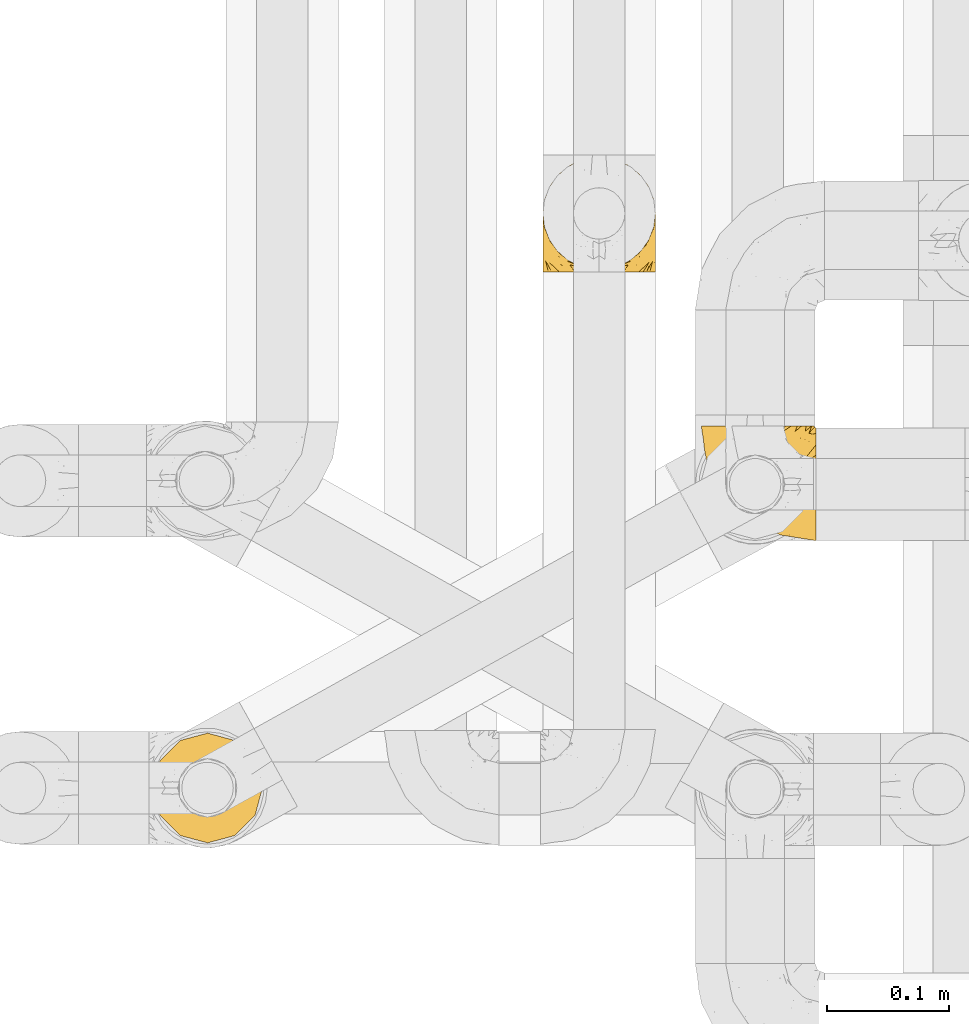
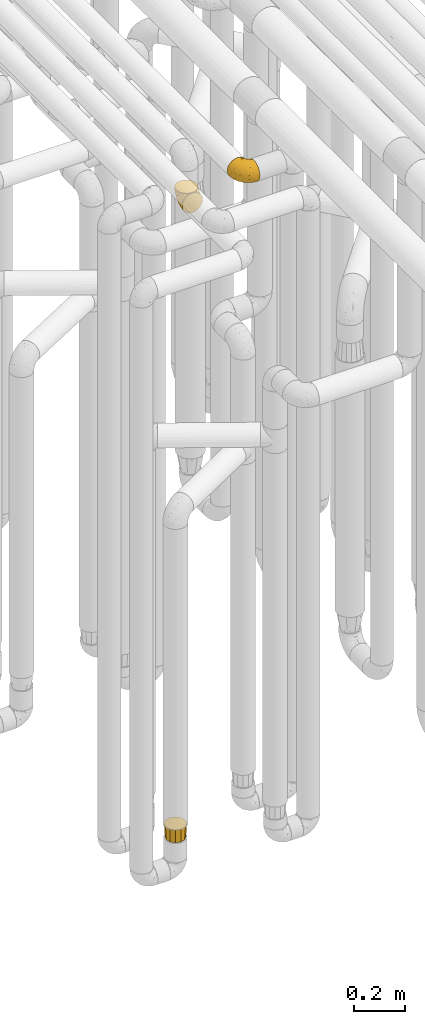
# One storey, part 150 of 827: 3 coverings.
"""IFC2X3 building model written with IfcOpenShell, lengths in millimetres."""

import ifcopenshell
import ifcopenshell.guid

model = None  # the IFC model being written
_history = None  # IfcOwnerHistory: only IFC2X3 demands one
_inside = {}  # id of a spatial element -> (the spatial element, [elements in it])
_under = {}  # id of a project, library or spatial element -> (it, [spatial elements below it])
_declared = {}  # id of a project -> (the project, [libraries it declares])
_typed = {}  # id of a type object -> (the type object, [elements of that type])
_made_of = {}  # id of a material, layer set ... -> (it, [elements and type objects made of it])


def new_model(schema):
    """Start an empty IFC model of exactly this schema.

    Asked for "IFC4X3", IfcOpenShell would pick the latest addendum, in which some entities
    have other attributes; the version numbers below select the first issue.
    IFC2X3 requires an IfcOwnerHistory on every rooted entity: one is made here for all.
    """
    global model, _history
    if schema == "IFC4X3":
        model = ifcopenshell.file(schema_version=(4, 3, 0, 0))
    else:
        model = ifcopenshell.file(schema=schema)
    _inside.clear()
    _under.clear()
    _declared.clear()
    _typed.clear()
    _made_of.clear()
    _history = None
    if model.schema == "IFC2X3":
        org = make("IfcOrganization", Name="unknown")
        user = make(
            "IfcPersonAndOrganization",
            ThePerson=make("IfcPerson", FamilyName="unknown"),
            TheOrganization=org,
        )
        app = make(
            "IfcApplication",
            ApplicationDeveloper=org,
            Version="unknown",
            ApplicationFullName="unknown",
            ApplicationIdentifier="unknown",
        )
        _history = make(
            "IfcOwnerHistory",
            OwningUser=user,
            OwningApplication=app,
            ChangeAction="ADDED",
            CreationDate=0,
        )
    return model


def make(cls, **values):
    """One entity of the class cls with the attributes given. An attribute that is None is left unset."""
    return model.create_entity(
        cls, **{name: value for name, value in values.items() if value is not None}
    )


def entity(cls, *values):
    """Any entity or typed value of the class cls, its attributes in the order of the schema. None: left unset."""
    e = model.create_entity(cls)
    for i, value in enumerate(values):
        if value is not None:
            e[i] = value
    return e


def rooted(cls, **values):
    """An entity with a GlobalId (a new one), such as an element, a storey or a relation."""
    return make(cls, GlobalId=ifcopenshell.guid.new(), OwnerHistory=_history, **values)


def si_unit(unit_type, name, prefix=None):
    """IfcSIUnit, for example si_unit("LENGTHUNIT", "METRE", prefix="MILLI")."""
    return make("IfcSIUnit", UnitType=unit_type, Prefix=prefix, Name=name)


def converted_unit(unit_type, name, factor, base, dimensions=None, offset=None):
    """IfcConversionBasedUnit, such as the inch: factor (a typed value) times the base unit."""
    return make(
        "IfcConversionBasedUnit"
        if offset is None
        else "IfcConversionBasedUnitWithOffset",
        ConversionOffset=offset,
        Dimensions=None
        if dimensions is None
        else entity("IfcDimensionalExponents", *dimensions),
        UnitType=unit_type,
        Name=name,
        ConversionFactor=make(
            "IfcMeasureWithUnit", ValueComponent=factor, UnitComponent=base
        ),
    )


def derived_unit(unit_type, elements):
    """IfcDerivedUnit: a product of units, each with its exponent."""
    return make(
        "IfcDerivedUnit",
        Elements=[
            make("IfcDerivedUnitElement", Unit=unit, Exponent=power)
            for unit, power in elements
        ],
        UnitType=unit_type,
    )


def assignment(units):
    """IfcUnitAssignment: the units of a project."""
    return None if units is None else make("IfcUnitAssignment", Units=units)


def point(xyz):
    """IfcCartesianPoint."""
    return None if xyz is None else make("IfcCartesianPoint", Coordinates=xyz)


def direction(xyz):
    """IfcDirection."""
    return None if xyz is None else make("IfcDirection", DirectionRatios=xyz)


def frame(location, z_axis=None, x_axis=None):
    """IfcAxis2Placement3D, a coordinate frame: its origin and axes. An axis left out is left unset."""
    return make(
        "IfcAxis2Placement3D",
        Location=point(location),
        Axis=direction(z_axis),
        RefDirection=direction(x_axis),
    )


def origin():
    """The frame at (0, 0, 0) with its axes left unset."""
    return frame((0.0, 0.0, 0.0))


def place(relative_to, where):
    """IfcLocalPlacement: puts the frame where relative to a parent placement (None: the world)."""
    return make(
        "IfcLocalPlacement", PlacementRelTo=relative_to, RelativePlacement=where
    )


def context(
    kind, dimensions, precision=None, world=None, true_north=None, identifier=None
):
    """IfcGeometricRepresentationContext, for example the 3D "Model" context."""
    return make(
        "IfcGeometricRepresentationContext",
        ContextIdentifier=identifier,
        ContextType=kind,
        CoordinateSpaceDimension=dimensions,
        Precision=precision,
        WorldCoordinateSystem=world,
        TrueNorth=true_north,
    )


def subcontext(parent, identifier, kind, view, scale=None):
    """IfcGeometricRepresentationSubContext, for example "Body" below "Model"."""
    return make(
        "IfcGeometricRepresentationSubContext",
        ContextIdentifier=identifier,
        ContextType=kind,
        ParentContext=parent,
        TargetScale=scale,
        TargetView=view,
    )


def project(units=None, contexts=None):
    """IfcProject with its units and contexts."""
    return rooted(
        "IfcProject",
        Name="project",
        RepresentationContexts=contexts,
        UnitsInContext=assignment(units),
    )


def spatial(cls, under=None, at=None, **own):
    """A site, building, storey or space (cls), placed at a placement, below another one or the project."""
    s = rooted(cls, ObjectPlacement=at, **own)
    if under is not None:
        _under.setdefault(under.id(), (under, []))[1].append(s)
    return s


def faces_of(points, faces, orient=None, outer=None):
    """IfcFace entities. A face is a list of loops; a loop is a list of indices into points, from 0.

    orient and outer hold one flag for each loop. By default every Orientation is true, the
    first loop of a face is its IfcFaceOuterBound and the others are IfcFaceBound.
    """
    made = []
    for i, loops in enumerate(faces):
        bounds = []
        for j, loop in enumerate(loops):
            is_outer = j == 0 if outer is None else outer[i][j]
            bounds.append(
                make(
                    "IfcFaceOuterBound" if is_outer else "IfcFaceBound",
                    Bound=make("IfcPolyLoop", Polygon=[points[k] for k in loop]),
                    Orientation=True if orient is None else orient[i][j],
                )
            )
        made.append(make("IfcFace", Bounds=bounds))
    return made


def faceted_brep(points, faces, orient=None, outer=None, voids=None):
    """IfcFacetedBrep: a solid bounded by flat faces; with voids (closed shells), ...WithVoids."""
    shared = [point(p) for p in points]
    hull = make("IfcClosedShell", CfsFaces=faces_of(shared, faces, orient, outer))
    if voids is None:
        return make("IfcFacetedBrep", Outer=hull)
    return make(
        "IfcFacetedBrepWithVoids",
        Outer=hull,
        Voids=[
            make(cls, CfsFaces=faces_of(shared, fs, o, b)) for cls, fs, o, b in voids
        ],
    )


def shape(context_of_items, identifier, shape_type, items):
    """IfcShapeRepresentation: the items that make up one representation, for example the "Body"."""
    return make(
        "IfcShapeRepresentation",
        ContextOfItems=context_of_items,
        RepresentationIdentifier=identifier,
        RepresentationType=shape_type,
        Items=items,
    )


def made_of(thing, what):
    """Note that an element or type object is made of a material, layer set ...; save() writes the relation."""
    if what is not None:
        _made_of.setdefault(what.id(), (what, []))[1].append(thing)
    return thing


def element(
    cls,
    number,
    at=None,
    inside=None,
    cuts=None,
    type_object=None,
    material=None,
    context=None,
    identifier="Body",
    shape_type=None,
    held_by="IfcProductDefinitionShape",
    body=None,
    shapes=None,
    **own,
):
    """One element of the class cls, such as IfcWall. Its Tag is "e" and its number.

    at: its placement. inside: the storey or other place that contains it. cuts: it is an
    opening in that element (IfcRelVoidsElement). A single representation is given by context,
    identifier, shape_type and body (its items); several are given by shapes. held_by: the class
    of the entity that holds the representations. save() writes the other relations.
    """
    e = rooted(cls, Tag="e%d" % number, ObjectPlacement=at, **own)
    if body is not None:
        shapes = [shape(context, identifier, shape_type, body)]
    if shapes is not None:
        e.Representation = make(held_by, Representations=shapes)
    if inside is not None:
        _inside.setdefault(inside.id(), (inside, []))[1].append(e)
    if cuts is not None:
        rooted(
            "IfcRelVoidsElement", RelatingBuildingElement=cuts, RelatedOpeningElement=e
        )
    if type_object is not None:
        _typed.setdefault(type_object.id(), (type_object, []))[1].append(e)
    return made_of(e, material)


def aggregate(whole, parts):
    """IfcRelAggregates: a whole, such as a stair, and the parts it consists of."""
    return rooted("IfcRelAggregates", RelatingObject=whole, RelatedObjects=parts)


def save(model, path):
    """Write the relations noted so far, then the file.

    IfcRelAggregates (storeys below a building ...), IfcRelContainedInSpatialStructure (elements
    in a storey), IfcRelDefinesByType, IfcRelAssociatesMaterial and IfcRelDeclares: one each for
    every whole, place, type object, material and project.
    """
    for whole, parts in _under.values():
        aggregate(whole, parts)
    for where, things in _inside.values():
        rooted(
            "IfcRelContainedInSpatialStructure",
            RelatedElements=things,
            RelatingStructure=where,
        )
    for kind, things in _typed.values():
        rooted("IfcRelDefinesByType", RelatedObjects=things, RelatingType=kind)
    for what, things in _made_of.values():
        rooted("IfcRelAssociatesMaterial", RelatedObjects=things, RelatingMaterial=what)
    for by, libraries in _declared.values():
        rooted("IfcRelDeclares", RelatingContext=by, RelatedDefinitions=libraries)
    model.write(path)


model = new_model("IFC2X3")

# Units and contexts
model_context = context("Model", 3, precision=0.01, world=origin(), true_north=direction((6.12303176911189e-17, 1.0)))
body_context = subcontext(model_context, "Body", "Model", "MODEL_VIEW")
ifc_project = project(units=[si_unit("LENGTHUNIT", "METRE", prefix="MILLI"), si_unit("AREAUNIT", "SQUARE_METRE"), si_unit("VOLUMEUNIT", "CUBIC_METRE"), converted_unit("PLANEANGLEUNIT", "DEGREE", entity("IfcRatioMeasure", 0.0174532925199433), si_unit("PLANEANGLEUNIT", "RADIAN"), dimensions=[0, 0, 0, 0, 0, 0, 0]), si_unit("MASSUNIT", "GRAM", prefix="KILO"), derived_unit("MASSDENSITYUNIT", [(si_unit("MASSUNIT", "GRAM", prefix="KILO"), 1), (si_unit("LENGTHUNIT", "METRE"), -3)]), derived_unit("MOMENTOFINERTIAUNIT", [(si_unit("LENGTHUNIT", "METRE"), 4)]), si_unit("TIMEUNIT", "SECOND"), si_unit("FREQUENCYUNIT", "HERTZ"), si_unit("THERMODYNAMICTEMPERATUREUNIT", "DEGREE_CELSIUS"), derived_unit("THERMALTRANSMITTANCEUNIT", [(si_unit("MASSUNIT", "GRAM", prefix="KILO"), 1), (si_unit("THERMODYNAMICTEMPERATUREUNIT", "KELVIN"), -1), (si_unit("TIMEUNIT", "SECOND"), -3)]), derived_unit("VOLUMETRICFLOWRATEUNIT", [(si_unit("LENGTHUNIT", "METRE"), 3), (si_unit("TIMEUNIT", "SECOND"), -1)]), derived_unit("MASSFLOWRATEUNIT", [(si_unit("MASSUNIT", "GRAM", prefix="KILO"), 1), (si_unit("TIMEUNIT", "SECOND"), -1)]), derived_unit("ROTATIONALFREQUENCYUNIT", [(si_unit("TIMEUNIT", "SECOND"), -1)]), si_unit("ELECTRICCURRENTUNIT", "AMPERE"), si_unit("ELECTRICVOLTAGEUNIT", "VOLT"), si_unit("POWERUNIT", "WATT"), si_unit("FORCEUNIT", "NEWTON", prefix="KILO"), si_unit("ILLUMINANCEUNIT", "LUX"), si_unit("LUMINOUSFLUXUNIT", "LUMEN"), si_unit("LUMINOUSINTENSITYUNIT", "CANDELA"), derived_unit("USERDEFINED", [(si_unit("MASSUNIT", "GRAM", prefix="KILO"), -1), (si_unit("LENGTHUNIT", "METRE"), -2), (si_unit("TIMEUNIT", "SECOND"), 3), (si_unit("LUMINOUSFLUXUNIT", "LUMEN"), 1)]), derived_unit("LINEARVELOCITYUNIT", [(si_unit("LENGTHUNIT", "METRE"), 1), (si_unit("TIMEUNIT", "SECOND"), -1)]), si_unit("PRESSUREUNIT", "PASCAL"), derived_unit("USERDEFINED", [(si_unit("LENGTHUNIT", "METRE"), -2), (si_unit("MASSUNIT", "GRAM", prefix="KILO"), 1), (si_unit("TIMEUNIT", "SECOND"), -2)]), derived_unit("LINEARFORCEUNIT", [(si_unit("MASSUNIT", "GRAM", prefix="KILO"), 1), (si_unit("LENGTHUNIT", "METRE"), 1), (si_unit("TIMEUNIT", "SECOND"), -2), (si_unit("LENGTHUNIT", "METRE"), -1)]), derived_unit("PLANARFORCEUNIT", [(si_unit("MASSUNIT", "GRAM", prefix="KILO"), 1), (si_unit("LENGTHUNIT", "METRE"), 1), (si_unit("TIMEUNIT", "SECOND"), -2), (si_unit("LENGTHUNIT", "METRE"), -2)])], contexts=[model_context])

# Site, building, storey
site_placement = place(None, origin())
site = spatial("IfcSite", under=ifc_project, at=site_placement, CompositionType="ELEMENT")
building_placement = place(site_placement, origin())
building = spatial("IfcBuilding", under=site, at=building_placement, CompositionType="ELEMENT")
storey_placement = place(building_placement, frame((0.0, 0.0, 28200.0)))
storey = spatial("IfcBuildingStorey", under=building, at=storey_placement, Name="08", CompositionType="ELEMENT", Elevation=28200.0)

# Coverings
covering_1_placement = place(storey_placement, frame((35552.3, 10778.78, 3152.2)))
element("IfcCovering", 1, at=covering_1_placement, inside=storey, Name=":ADSK_", ObjectType=":ADSK_", PredefinedType="INSULATION", context=body_context, shape_type="Brep", body=[
    faceted_brep([(11.68, 1.6, 18.98), (19.0, 1.6, 11.67), (27.76, 1.6, 6.17), (37.52, 1.6, 2.75), (47.8, 1.6, 1.6), (58.08, 1.6, 2.75), (67.85, 1.6, 6.17), (76.61, 1.6, 11.68), (83.92, 1.6, 19.0), (89.42, 1.6, 27.76), (92.84, 1.6, 37.52), (94.0, 1.6, 47.8), (93.53, 1.6, 51.94), (93.18, 1.6, 55.01), (92.84, 1.6, 58.08), (91.13, 1.6, 62.96), (89.42, 1.6, 67.85), (86.66, 1.6, 72.23), (83.91, 1.6, 76.61), (80.25, 1.6, 80.26), (76.59, 1.6, 83.92), (67.83, 1.6, 89.42), (62.95, 1.6, 91.13), (58.07, 1.6, 92.84), (47.8, 1.6, 94.0), (37.51, 1.6, 92.84), (32.63, 1.6, 91.13), (27.74, 1.6, 89.42), (18.98, 1.6, 83.91), (15.33, 1.6, 80.25), (11.67, 1.6, 76.59), (8.92, 1.6, 72.21), (6.17, 1.6, 67.83), (4.46, 1.6, 62.95), (2.75, 1.6, 58.07), (2.41, 1.6, 55.0), (2.06, 1.6, 51.94), (1.6, 1.6, 47.8), (2.75, 1.6, 37.51), (6.17, 1.6, 27.74), (47.8, 3.4, 95.8), (59.75, 4.97, 95.8), (70.9, 9.58, 95.8), (75.68, 13.26, 95.8), (80.46, 16.93, 95.8), (84.13, 21.71, 95.8), (87.81, 26.5, 95.8), (90.11, 32.07, 95.8), (92.42, 37.64, 95.8), (92.9, 41.25, 95.8), (93.17, 43.34, 95.8), (93.45, 45.42, 95.8), (94.0, 49.6, 95.8), (92.42, 61.55, 95.8), (87.81, 72.7, 95.8), (80.46, 82.26, 95.8), (70.9, 89.61, 95.8), (59.75, 94.22, 95.8), (47.8, 95.8, 95.8), (35.84, 94.22, 95.8), (24.7, 89.61, 95.8), (15.13, 82.26, 95.8), (7.78, 72.7, 95.8), (3.17, 61.55, 95.8), (1.6, 49.6, 95.8), (2.14, 45.42, 95.8), (2.69, 41.25, 95.8), (3.17, 37.64, 95.8), (5.48, 32.07, 95.8), (7.78, 26.5, 95.8), (11.46, 21.71, 95.8), (15.13, 16.93, 95.8), (19.91, 13.26, 95.8), (24.7, 9.58, 95.8), (35.84, 4.97, 95.8), (23.61, 81.55, 60.58), (31.99, 90.4, 74.11), (35.87, 83.0, 51.59), (47.8, 91.18, 66.69), (40.43, 93.13, 76.19), (47.8, 94.0, 84.43), (31.83, 66.19, 31.2), (23.37, 70.92, 42.88), (21.41, 85.95, 79.41), (3.07, 49.74, 60.7), (1.6, 35.54, 61.85), (1.6, 38.14, 65.75), (1.6, 40.74, 69.64), (1.6, 43.34, 73.53), (1.6, 45.94, 77.43), (13.45, 77.59, 74.59), (15.25, 71.17, 54.72), (8.07, 65.81, 64.18), (16.0, 59.03, 37.94), (17.34, 45.85, 25.89), (10.58, 45.79, 34.73), (5.34, 41.42, 42.89), (2.39, 34.51, 49.83), (8.36, 56.04, 48.58), (10.04, 15.15, 22.41), (2.59, 56.51, 78.69), (6.28, 68.39, 81.64), (34.28, 23.33, 6.22), (38.73, 42.86, 12.11), (27.25, 39.42, 14.81), (29.88, 53.58, 21.61), (38.6, 59.17, 22.41), (23.44, 59.06, 30.12), (25.25, 22.63, 10.01), (17.23, 20.55, 15.36), (47.8, 12.96, 3.39), (47.8, 56.96, 19.59), (47.8, 67.38, 30.01), (2.53, 18.72, 41.19), (1.6, 5.33, 48.54), (1.6, 9.07, 49.28), (1.6, 11.79, 49.82), (1.6, 14.51, 50.37), (1.6, 17.24, 50.91), (1.6, 19.96, 51.45), (5.71, 21.03, 31.61), (1.6, 46.48, 80.15), (1.6, 47.03, 82.88), (1.6, 47.57, 85.6), (1.6, 48.11, 88.32), (1.6, 48.48, 90.19), (1.6, 48.85, 92.06), (47.8, 30.7, 6.21), (1.6, 23.86, 54.05), (1.6, 27.75, 56.65), (1.6, 31.64, 59.25), (11.89, 31.26, 24.66), (47.8, 77.8, 40.43), (39.69, 72.75, 35.17), (47.8, 43.83, 12.9), (47.8, 84.49, 53.56), (13.84, 14.58, 85.34), (9.16, 16.17, 78.44), (15.79, 10.82, 84.37), (25.75, 4.64, 89.05), (16.09, 7.71, 82.76), (7.51, 25.13, 86.31), (3.99, 32.66, 83.73), (2.66, 34.94, 77.31), (3.16, 36.76, 87.78), (2.35, 40.48, 87.91), (2.23, 39.25, 81.29), (38.35, 3.69, 93.97), (6.18, 13.99, 70.76), (2.7, 21.85, 63.67), (2.93, 17.93, 62.62), (16.01, 15.11, 90.64), (9.08, 21.14, 84.08), (11.68, 7.21, 77.45), (6.83, 9.47, 70.34), (4.65, 32.27, 88.72), (3.65, 25.68, 71.28), (3.61, 22.18, 68.09), (12.8, 18.79, 91.07), (2.43, 10.12, 57.47), (21.65, 10.45, 91.35), (3.7, 11.29, 62.99), (47.8, 2.87, 94.52), (3.37, 31.16, 76.47), (9.3, 12.7, 76.28), (7.03, 6.31, 69.96), (7.87, 25.62, 89.86), (7.26, 21.18, 78.94), (3.41, 28.81, 73.51), (23.81, 7.45, 89.62), (88.32, 21.17, 78.96), (86.42, 16.17, 78.46), (91.93, 25.69, 71.31), (94.0, 48.85, 92.06), (94.0, 47.03, 82.88), (94.0, 47.57, 85.6), (94.0, 48.11, 88.32), (57.24, 3.69, 93.97), (71.76, 7.44, 89.63), (94.0, 14.51, 50.37), (94.0, 11.79, 49.82), (94.0, 5.33, 48.54), (94.0, 9.07, 49.28), (79.49, 7.71, 82.77), (88.75, 9.47, 70.36), (92.93, 34.94, 77.31), (92.22, 31.16, 76.47), (94.0, 40.74, 69.64), (94.0, 38.14, 65.75), (82.79, 18.79, 91.06), (92.43, 36.76, 87.78), (93.24, 40.48, 87.91), (69.82, 4.63, 89.06), (86.5, 21.14, 84.09), (79.57, 15.11, 90.65), (81.74, 14.58, 85.35), (94.0, 43.34, 73.53), (94.0, 45.94, 77.43), (93.36, 39.25, 81.29), (83.9, 7.21, 77.46), (86.28, 12.69, 76.29), (93.16, 10.14, 57.47), (92.88, 21.81, 63.71), (91.98, 22.19, 68.11), (89.41, 14.0, 70.77), (88.82, 6.66, 69.52), (92.66, 17.92, 62.64), (73.93, 10.45, 91.35), (94.0, 31.64, 59.25), (79.5, 10.64, 84.6), (91.89, 11.31, 62.98), (94.0, 19.96, 51.45), (94.0, 23.86, 54.05), (94.0, 27.75, 56.65), (91.6, 32.66, 83.73), (94.0, 46.48, 80.15), (90.94, 32.27, 88.72), (88.08, 25.13, 86.3), (94.0, 35.54, 61.85), (92.16, 28.77, 73.56), (86.13, 23.36, 91.36), (94.0, 17.24, 50.91), (93.2, 47.58, 62.87), (55.16, 93.13, 76.19), (82.02, 77.44, 73.57), (84.29, 66.78, 56.07), (76.94, 71.68, 49.77), (68.33, 74.96, 44.73), (71.98, 81.55, 60.58), (92.52, 36.7, 47.64), (92.9, 56.9, 78.32), (59.72, 83.0, 51.59), (63.6, 90.4, 74.11), (88.89, 67.83, 76.04), (74.18, 85.95, 79.41), (68.35, 39.41, 14.82), (61.33, 23.33, 6.22), (56.86, 42.87, 12.12), (68.62, 53.92, 23.51), (63.76, 66.19, 31.2), (72.19, 64.12, 34.96), (88.69, 33.13, 33.86), (92.19, 23.1, 38.94), (89.75, 16.98, 30.23), (55.9, 72.75, 35.17), (77.99, 23.77, 15.85), (85.21, 18.41, 22.59), (74.99, 43.7, 21.56), (90.23, 54.53, 55.94), (59.86, 55.72, 20.67), (70.75, 17.73, 9.19), (81.72, 38.98, 25.79), (86.53, 50.28, 41.16), (79.6, 59.02, 37.95)], [[[0, 1, 2, 3, 4, 5, 6, 7, 8, 9, 10, 11, 12, 13, 14, 15, 16, 17, 18, 19, 20, 21, 22, 23, 24, 25, 26, 27, 28, 29, 30, 31, 32, 33, 34, 35, 36, 37, 38, 39]], [[40, 41, 42, 43, 44, 45, 46, 47, 48, 49, 50, 51, 52, 53, 54, 55, 56, 57, 58, 59, 60, 61, 62, 63, 64, 65, 66, 67, 68, 69, 70, 71, 72, 73, 74]], [[75, 76, 77]], [[78, 79, 80]], [[77, 81, 82]], [[76, 75, 83]], [[84, 85, 86, 87, 88, 89]], [[90, 91, 92]], [[76, 60, 59]], [[93, 94, 95]], [[90, 62, 61]], [[83, 61, 60]], [[96, 97, 84]], [[98, 93, 95]], [[0, 39, 99]], [[100, 84, 89]], [[62, 101, 63]], [[2, 102, 3]], [[92, 84, 100]], [[103, 102, 104]], [[103, 105, 106]], [[93, 107, 94]], [[1, 108, 2]], [[92, 101, 90]], [[108, 1, 109]], [[102, 110, 3]], [[93, 82, 107]], [[102, 108, 104]], [[111, 106, 112]], [[109, 0, 99]], [[113, 37, 114, 115, 116, 117, 118, 119]], [[120, 38, 113]], [[100, 89, 121, 122, 123, 124, 125, 126, 64]], [[127, 102, 103]], [[97, 119, 128, 129, 130, 85]], [[99, 120, 131]], [[132, 133, 77]], [[59, 80, 79]], [[1, 0, 109]], [[98, 84, 92]], [[94, 109, 131]], [[120, 39, 38]], [[93, 91, 82]], [[104, 94, 105]], [[97, 113, 119]], [[95, 120, 96]], [[83, 90, 61]], [[91, 93, 98]], [[64, 63, 100]], [[100, 63, 101]], [[77, 76, 79]], [[133, 106, 81]], [[84, 97, 85]], [[113, 96, 120]], [[113, 97, 96]], [[37, 113, 38]], [[110, 102, 127]], [[110, 4, 3]], [[103, 111, 134, 127]], [[90, 75, 91]], [[82, 81, 107]], [[91, 75, 82]], [[77, 82, 75]], [[76, 83, 60]], [[90, 83, 75]], [[105, 107, 81]], [[94, 131, 95]], [[105, 94, 107]], [[109, 94, 104]], [[120, 95, 131]], [[98, 95, 96]], [[84, 98, 96]], [[98, 92, 91]], [[106, 105, 81]], [[103, 104, 105]], [[112, 106, 133]], [[103, 106, 111]], [[112, 133, 132]], [[81, 77, 133]], [[77, 78, 135, 132]], [[120, 99, 39]], [[109, 99, 131]], [[59, 58, 80]], [[59, 79, 76]], [[90, 101, 62]], [[100, 101, 92]], [[2, 108, 102]], [[109, 104, 108]], [[78, 77, 79]], [[136, 137, 138]], [[27, 139, 140]], [[141, 142, 143]], [[144, 145, 121]], [[146, 89, 88]], [[147, 139, 25]], [[148, 149, 150]], [[136, 151, 152]], [[147, 40, 74]], [[24, 147, 25]], [[153, 148, 154]], [[33, 116, 34]], [[73, 72, 151]], [[114, 37, 36, 35, 34, 116, 115]], [[146, 155, 144]], [[156, 85, 130]], [[157, 149, 148]], [[151, 158, 152]], [[117, 33, 159]], [[29, 153, 154]], [[160, 74, 73]], [[161, 128, 119]], [[65, 64, 126, 125, 124, 123, 122, 67, 66]], [[162, 147, 24]], [[27, 140, 28]], [[149, 129, 150]], [[139, 27, 26, 25]], [[68, 144, 69]], [[129, 128, 150]], [[163, 87, 86]], [[130, 129, 149]], [[122, 145, 67]], [[153, 164, 148]], [[161, 119, 159]], [[165, 30, 154]], [[150, 154, 148]], [[128, 161, 150]], [[30, 165, 31]], [[145, 144, 68]], [[89, 146, 144]], [[87, 163, 143]], [[166, 155, 142]], [[88, 87, 143]], [[161, 154, 150]], [[154, 30, 29]], [[29, 28, 153]], [[28, 140, 153]], [[164, 153, 140]], [[140, 137, 164]], [[157, 148, 164]], [[156, 130, 157]], [[164, 137, 157]], [[157, 137, 156]], [[167, 137, 136]], [[168, 85, 156]], [[152, 168, 167]], [[167, 168, 156]], [[163, 152, 141]], [[71, 158, 72]], [[152, 167, 136]], [[88, 142, 146]], [[144, 155, 69]], [[146, 142, 155]], [[70, 166, 71]], [[142, 141, 166]], [[70, 69, 155]], [[141, 158, 71]], [[160, 73, 151]], [[138, 137, 140]], [[160, 136, 169]], [[136, 160, 151]], [[74, 160, 169]], [[152, 158, 141]], [[151, 72, 158]], [[168, 152, 163]], [[137, 167, 156]], [[163, 86, 168]], [[85, 168, 86]], [[116, 33, 117]], [[130, 149, 157]], [[67, 145, 68]], [[121, 89, 144]], [[145, 122, 121]], [[40, 147, 162]], [[169, 147, 74]], [[159, 33, 32]], [[161, 159, 32]], [[159, 119, 118, 117]], [[139, 147, 169]], [[139, 169, 138]], [[161, 32, 31]], [[141, 143, 163]], [[88, 143, 142]], [[71, 166, 141]], [[155, 166, 70]], [[139, 138, 140]], [[169, 136, 138]], [[154, 161, 165]], [[161, 31, 165]], [[170, 171, 172]], [[173, 52, 51, 50, 49, 48, 174, 175, 176]], [[177, 178, 41]], [[179, 15, 180]], [[12, 11, 181, 182, 180, 14, 13]], [[183, 21, 20]], [[19, 18, 184]], [[185, 186, 187]], [[186, 188, 187]], [[43, 189, 44]], [[190, 191, 47]], [[23, 22, 21, 192]], [[193, 194, 195]], [[40, 162, 177]], [[196, 197, 198]], [[24, 23, 177]], [[199, 200, 183]], [[201, 15, 179]], [[47, 46, 190]], [[202, 203, 204]], [[203, 172, 171]], [[205, 206, 184]], [[207, 41, 178]], [[16, 15, 201]], [[14, 180, 15]], [[204, 203, 200]], [[208, 203, 202]], [[162, 24, 177]], [[48, 47, 191]], [[198, 197, 190]], [[199, 184, 204]], [[171, 195, 209]], [[210, 211, 212]], [[206, 212, 213]], [[205, 17, 210]], [[184, 206, 204]], [[210, 212, 206]], [[185, 196, 214]], [[190, 215, 191]], [[216, 45, 214]], [[186, 217, 193]], [[190, 216, 198]], [[199, 20, 19]], [[196, 185, 187]], [[199, 183, 20]], [[184, 199, 19]], [[199, 204, 200]], [[206, 202, 204]], [[171, 183, 200]], [[203, 208, 172]], [[172, 208, 218]], [[171, 200, 203]], [[218, 188, 219]], [[195, 170, 193]], [[217, 186, 185]], [[193, 219, 186]], [[193, 170, 219]], [[207, 194, 42]], [[217, 220, 189]], [[216, 190, 46]], [[214, 196, 198]], [[44, 220, 45]], [[214, 198, 216]], [[216, 46, 45]], [[214, 45, 220]], [[42, 194, 43]], [[189, 193, 217]], [[207, 195, 194]], [[209, 195, 178]], [[41, 207, 42]], [[195, 207, 178]], [[43, 194, 189]], [[193, 189, 194]], [[171, 170, 195]], [[170, 172, 219]], [[218, 219, 172]], [[188, 186, 219]], [[206, 213, 202]], [[208, 202, 213]], [[201, 210, 16]], [[215, 190, 197]], [[215, 174, 191]], [[174, 48, 191]], [[201, 179, 221, 211]], [[210, 201, 211]], [[23, 192, 177]], [[40, 177, 41]], [[183, 209, 192]], [[183, 192, 21]], [[192, 178, 177]], [[205, 18, 17]], [[17, 16, 210]], [[217, 185, 214]], [[189, 220, 44]], [[214, 220, 217]], [[192, 209, 178]], [[171, 209, 183]], [[206, 205, 210]], [[18, 205, 184]], [[222, 197, 196, 187, 188, 218]], [[57, 223, 80]], [[224, 225, 226]], [[226, 227, 228]], [[229, 218, 208, 213, 212, 211]], [[230, 52, 173, 176, 175, 174, 215, 197]], [[231, 232, 228]], [[231, 78, 223]], [[223, 57, 232]], [[224, 233, 225]], [[233, 54, 53]], [[234, 232, 56]], [[56, 55, 234]], [[234, 224, 228]], [[235, 236, 237]], [[224, 55, 54]], [[238, 239, 240]], [[52, 230, 53]], [[241, 242, 243]], [[227, 244, 231]], [[11, 10, 242]], [[236, 6, 5]], [[7, 245, 8]], [[8, 246, 9]], [[238, 247, 235]], [[222, 229, 248]], [[242, 211, 221, 179, 180, 182, 181, 11]], [[233, 53, 230]], [[111, 112, 249]], [[250, 6, 236]], [[246, 251, 241]], [[6, 250, 7]], [[127, 236, 110]], [[248, 229, 252]], [[246, 8, 245]], [[235, 245, 250]], [[236, 5, 110]], [[235, 249, 238]], [[237, 236, 127]], [[243, 9, 246]], [[252, 229, 241]], [[56, 232, 57]], [[222, 230, 197]], [[225, 248, 252]], [[248, 233, 230]], [[54, 233, 224]], [[231, 228, 227]], [[244, 132, 231]], [[248, 225, 233]], [[226, 225, 253]], [[235, 250, 236]], [[245, 7, 250]], [[251, 246, 245]], [[243, 246, 241]], [[247, 245, 235]], [[252, 251, 253]], [[229, 222, 218]], [[230, 222, 248]], [[5, 4, 110]], [[237, 127, 134, 111]], [[238, 249, 239]], [[224, 234, 55]], [[232, 234, 228]], [[242, 241, 229]], [[10, 9, 243]], [[211, 242, 229]], [[10, 243, 242]], [[80, 223, 78]], [[80, 58, 57]], [[231, 223, 232]], [[227, 240, 239]], [[224, 226, 228]], [[240, 226, 253]], [[227, 239, 244]], [[226, 240, 227]], [[251, 247, 253]], [[240, 253, 247]], [[249, 235, 237]], [[237, 111, 249]], [[112, 132, 244]], [[112, 244, 249]], [[78, 231, 132, 135]], [[249, 244, 239]], [[247, 238, 240]], [[245, 247, 251]], [[251, 252, 241]], [[225, 252, 253]]]),
])
covering_2_placement = place(storey_placement, frame((35682.24, 10558.41, 3352.2)))
element("IfcCovering", 2, at=covering_2_placement, inside=storey, Name=":ADSK_", ObjectType=":ADSK_", PredefinedType="INSULATION", context=body_context, shape_type="Brep", body=[
    faceted_brep([(95.8, 18.98, 83.91), (95.8, 11.67, 76.59), (95.8, 6.17, 67.83), (95.8, 2.75, 58.07), (95.8, 1.6, 47.8), (95.8, 2.75, 37.51), (95.8, 6.17, 27.74), (95.8, 11.68, 18.98), (95.8, 19.0, 11.67), (95.8, 27.76, 6.17), (95.8, 37.52, 2.75), (95.8, 47.8, 1.6), (95.8, 51.94, 2.06), (95.8, 55.01, 2.41), (95.8, 58.08, 2.75), (95.8, 62.96, 4.46), (95.8, 67.85, 6.17), (95.8, 72.23, 8.93), (95.8, 76.61, 11.68), (95.8, 80.26, 15.34), (95.8, 83.92, 19.0), (95.8, 89.42, 27.76), (95.8, 91.13, 32.64), (95.8, 92.84, 37.52), (95.8, 94.0, 47.8), (95.8, 92.84, 58.08), (95.8, 91.13, 62.96), (95.8, 89.42, 67.85), (95.8, 83.91, 76.61), (95.8, 80.25, 80.26), (95.8, 76.59, 83.92), (95.8, 72.21, 86.67), (95.8, 67.83, 89.42), (95.8, 62.95, 91.13), (95.8, 58.07, 92.84), (95.8, 55.0, 93.18), (95.8, 51.94, 93.53), (95.8, 47.8, 94.0), (95.8, 37.51, 92.84), (95.8, 27.74, 89.42), (94.0, 95.8, 47.8), (92.42, 95.8, 35.84), (87.81, 95.8, 24.7), (84.13, 95.8, 19.91), (80.46, 95.8, 15.13), (75.68, 95.8, 11.46), (70.9, 95.8, 7.78), (65.32, 95.8, 5.48), (59.75, 95.8, 3.17), (56.14, 95.8, 2.69), (54.06, 95.8, 2.42), (51.97, 95.8, 2.14), (47.8, 95.8, 1.6), (35.84, 95.8, 3.17), (24.7, 95.8, 7.78), (15.13, 95.8, 15.13), (7.78, 95.8, 24.7), (3.17, 95.8, 35.84), (1.6, 95.8, 47.8), (3.17, 95.8, 59.75), (7.78, 95.8, 70.9), (15.13, 95.8, 80.46), (24.7, 95.8, 87.81), (35.84, 95.8, 92.42), (47.8, 95.8, 94.0), (51.97, 95.8, 93.45), (56.14, 95.8, 92.9), (59.75, 95.8, 92.42), (65.32, 95.8, 90.11), (70.9, 95.8, 87.81), (75.68, 95.8, 84.13), (80.46, 95.8, 80.46), (84.13, 95.8, 75.68), (87.81, 95.8, 70.9), (92.42, 95.8, 59.75), (15.84, 60.58, 71.98), (6.99, 74.11, 63.6), (14.39, 51.59, 59.72), (6.21, 66.69, 47.8), (4.26, 76.19, 55.16), (3.39, 84.43, 47.8), (31.2, 31.2, 63.76), (26.47, 42.88, 72.22), (11.44, 79.41, 74.18), (47.66, 60.7, 92.52), (61.85, 61.85, 94.0), (59.25, 65.75, 94.0), (56.65, 69.64, 94.0), (54.05, 73.53, 94.0), (51.45, 77.43, 94.0), (19.8, 74.59, 82.14), (26.22, 54.72, 80.34), (31.58, 64.18, 87.52), (38.36, 37.94, 79.59), (51.54, 25.89, 78.25), (51.6, 34.73, 85.01), (55.97, 42.89, 90.25), (62.88, 49.83, 93.2), (41.35, 48.58, 87.23), (82.24, 22.41, 85.55), (40.88, 78.69, 93.0), (29.0, 81.64, 89.31), (74.06, 6.22, 61.31), (54.53, 12.11, 56.86), (57.98, 14.81, 68.34), (43.81, 21.61, 65.71), (38.22, 22.41, 56.99), (38.33, 30.12, 72.15), (74.76, 10.01, 70.34), (76.85, 15.36, 78.36), (84.43, 3.39, 47.8), (40.43, 19.59, 47.8), (30.01, 30.01, 47.8), (78.67, 41.19, 93.06), (92.06, 48.54, 94.0), (88.32, 49.28, 94.0), (85.6, 49.82, 94.0), (82.88, 50.37, 94.0), (80.15, 50.91, 94.0), (77.43, 51.45, 94.0), (76.36, 31.61, 89.88), (50.91, 80.15, 94.0), (50.37, 82.88, 94.0), (49.82, 85.6, 94.0), (49.28, 88.32, 94.0), (48.91, 90.19, 94.0), (48.54, 92.06, 94.0), (66.69, 6.21, 47.8), (73.53, 54.05, 94.0), (69.64, 56.65, 94.0), (65.75, 59.25, 94.0), (66.13, 24.66, 83.7), (19.59, 40.43, 47.8), (24.64, 35.17, 55.9), (53.56, 12.9, 47.8), (12.9, 53.56, 47.8), (82.81, 85.34, 81.75), (81.22, 78.44, 86.43), (86.57, 84.37, 79.8), (92.75, 89.05, 69.84), (89.68, 82.76, 79.5), (72.26, 86.31, 88.08), (64.73, 83.73, 91.6), (62.45, 77.31, 92.93), (60.63, 87.78, 92.43), (56.91, 87.91, 93.24), (58.14, 81.29, 93.36), (93.7, 93.97, 57.25), (83.4, 70.76, 89.41), (75.54, 63.67, 92.89), (79.46, 62.62, 92.66), (82.28, 90.64, 79.58), (76.25, 84.08, 86.51), (90.18, 77.45, 83.91), (87.92, 70.34, 88.76), (65.12, 88.72, 90.94), (71.71, 71.28, 91.94), (75.21, 68.09, 91.98), (78.6, 91.07, 82.79), (87.27, 57.47, 93.16), (86.94, 91.35, 73.94), (86.1, 62.99, 91.89), (94.52, 94.52, 47.8), (66.23, 76.47, 92.22), (84.69, 76.28, 86.29), (91.08, 69.96, 88.56), (71.77, 89.86, 87.72), (76.21, 78.94, 88.33), (68.59, 73.51, 92.18), (89.94, 89.62, 71.78), (76.22, 78.96, 7.27), (81.22, 78.46, 9.17), (71.7, 71.31, 3.66), (49.28, 88.32, 1.6), (48.54, 92.06, 1.6), (50.37, 82.88, 1.6), (49.82, 85.6, 1.6), (93.7, 93.97, 38.35), (89.95, 89.63, 23.84), (82.88, 50.37, 1.6), (85.6, 49.82, 1.6), (92.06, 48.54, 1.6), (88.32, 49.28, 1.6), (89.68, 82.77, 16.1), (87.92, 70.36, 6.84), (62.45, 77.31, 2.66), (66.24, 76.47, 3.37), (56.65, 69.64, 1.6), (59.25, 65.75, 1.6), (78.6, 91.06, 12.8), (60.63, 87.78, 3.16), (56.91, 87.91, 2.35), (92.76, 89.06, 25.77), (76.25, 84.09, 9.09), (82.28, 90.65, 16.02), (82.81, 85.35, 13.85), (54.05, 73.53, 1.6), (51.45, 77.43, 1.6), (58.14, 81.29, 2.23), (90.18, 77.46, 11.69), (84.7, 76.29, 9.31), (87.25, 57.47, 2.43), (75.58, 63.71, 2.71), (75.2, 68.11, 3.61), (83.39, 70.77, 6.18), (90.73, 69.52, 6.77), (79.47, 62.64, 2.93), (86.94, 91.35, 21.66), (65.75, 59.25, 1.6), (86.75, 84.6, 16.09), (86.08, 62.98, 3.7), (77.43, 51.45, 1.6), (73.53, 54.05, 1.6), (69.64, 56.65, 1.6), (64.73, 83.73, 3.99), (50.91, 80.15, 1.6), (65.12, 88.72, 4.65), (72.26, 86.3, 7.51), (61.85, 61.85, 1.6), (68.62, 73.56, 3.43), (74.03, 91.36, 9.46), (80.15, 50.91, 1.6), (49.81, 62.87, 2.4), (4.26, 76.19, 40.43), (19.95, 73.57, 13.57), (30.61, 56.07, 11.3), (25.71, 49.77, 18.65), (22.43, 44.73, 27.26), (15.85, 60.58, 23.61), (60.69, 47.64, 3.07), (40.49, 78.32, 2.69), (14.39, 51.59, 35.87), (6.99, 74.11, 31.99), (29.56, 76.04, 6.71), (11.45, 79.41, 21.41), (57.98, 14.82, 27.24), (74.06, 6.22, 34.26), (54.52, 12.12, 38.73), (43.47, 23.51, 26.97), (31.2, 31.2, 31.83), (33.27, 34.96, 23.4), (64.26, 33.86, 6.91), (74.29, 38.94, 3.4), (80.41, 30.23, 5.84), (24.64, 35.17, 39.69), (73.62, 15.85, 17.6), (78.98, 22.59, 10.38), (53.69, 21.56, 20.6), (42.86, 55.94, 5.36), (41.67, 20.67, 35.73), (79.66, 9.19, 24.84), (58.41, 25.79, 13.87), (47.11, 41.16, 9.06), (38.37, 37.95, 15.99)], [[[0, 1, 2, 3, 4, 5, 6, 7, 8, 9, 10, 11, 12, 13, 14, 15, 16, 17, 18, 19, 20, 21, 22, 23, 24, 25, 26, 27, 28, 29, 30, 31, 32, 33, 34, 35, 36, 37, 38, 39]], [[40, 41, 42, 43, 44, 45, 46, 47, 48, 49, 50, 51, 52, 53, 54, 55, 56, 57, 58, 59, 60, 61, 62, 63, 64, 65, 66, 67, 68, 69, 70, 71, 72, 73, 74]], [[75, 76, 77]], [[78, 79, 80]], [[77, 81, 82]], [[76, 75, 83]], [[84, 85, 86, 87, 88, 89]], [[90, 91, 92]], [[76, 60, 59]], [[93, 94, 95]], [[90, 62, 61]], [[83, 61, 60]], [[96, 97, 84]], [[98, 93, 95]], [[0, 39, 99]], [[100, 84, 89]], [[62, 101, 63]], [[2, 102, 3]], [[92, 84, 100]], [[103, 102, 104]], [[103, 105, 106]], [[93, 107, 94]], [[1, 108, 2]], [[92, 101, 90]], [[108, 1, 109]], [[102, 110, 3]], [[93, 82, 107]], [[102, 108, 104]], [[111, 106, 112]], [[109, 0, 99]], [[113, 37, 114, 115, 116, 117, 118, 119]], [[120, 38, 113]], [[100, 89, 121, 122, 123, 124, 125, 126, 64]], [[127, 102, 103]], [[97, 119, 128, 129, 130, 85]], [[99, 120, 131]], [[132, 133, 77]], [[59, 80, 79]], [[1, 0, 109]], [[98, 84, 92]], [[94, 109, 131]], [[120, 39, 38]], [[93, 91, 82]], [[104, 94, 105]], [[97, 113, 119]], [[95, 120, 96]], [[83, 90, 61]], [[91, 93, 98]], [[64, 63, 100]], [[100, 63, 101]], [[77, 76, 79]], [[133, 106, 81]], [[84, 97, 85]], [[113, 96, 120]], [[113, 97, 96]], [[37, 113, 38]], [[110, 102, 127]], [[110, 4, 3]], [[103, 111, 134, 127]], [[90, 75, 91]], [[82, 81, 107]], [[91, 75, 82]], [[77, 82, 75]], [[76, 83, 60]], [[90, 83, 75]], [[105, 107, 81]], [[94, 131, 95]], [[105, 94, 107]], [[109, 94, 104]], [[120, 95, 131]], [[98, 95, 96]], [[84, 98, 96]], [[98, 92, 91]], [[106, 105, 81]], [[103, 104, 105]], [[112, 106, 133]], [[103, 106, 111]], [[112, 133, 132]], [[81, 77, 133]], [[77, 78, 135, 132]], [[120, 99, 39]], [[109, 99, 131]], [[59, 58, 80]], [[59, 79, 76]], [[90, 101, 62]], [[100, 101, 92]], [[2, 108, 102]], [[109, 104, 108]], [[78, 77, 79]], [[136, 137, 138]], [[27, 139, 140]], [[141, 142, 143]], [[144, 145, 121]], [[146, 89, 88]], [[147, 139, 25]], [[148, 149, 150]], [[136, 151, 152]], [[147, 40, 74]], [[24, 147, 25]], [[153, 148, 154]], [[33, 116, 34]], [[73, 72, 151]], [[114, 37, 36, 35, 34, 116, 115]], [[146, 155, 144]], [[156, 85, 130]], [[157, 149, 148]], [[151, 158, 152]], [[117, 33, 159]], [[29, 153, 154]], [[160, 74, 73]], [[161, 128, 119]], [[65, 64, 126, 125, 124, 123, 122, 67, 66]], [[162, 147, 24]], [[27, 140, 28]], [[149, 129, 150]], [[139, 27, 26, 25]], [[68, 144, 69]], [[129, 128, 150]], [[163, 87, 86]], [[130, 129, 149]], [[122, 145, 67]], [[153, 164, 148]], [[161, 119, 159]], [[165, 30, 154]], [[150, 154, 148]], [[128, 161, 150]], [[30, 165, 31]], [[145, 144, 68]], [[89, 146, 144]], [[87, 163, 143]], [[166, 155, 142]], [[88, 87, 143]], [[161, 154, 150]], [[154, 30, 29]], [[29, 28, 153]], [[28, 140, 153]], [[164, 153, 140]], [[140, 137, 164]], [[157, 148, 164]], [[156, 130, 157]], [[164, 137, 157]], [[157, 137, 156]], [[167, 137, 136]], [[168, 85, 156]], [[152, 168, 167]], [[167, 168, 156]], [[163, 152, 141]], [[71, 158, 72]], [[152, 167, 136]], [[88, 142, 146]], [[144, 155, 69]], [[146, 142, 155]], [[70, 166, 71]], [[142, 141, 166]], [[70, 69, 155]], [[141, 158, 71]], [[160, 73, 151]], [[138, 137, 140]], [[160, 136, 169]], [[136, 160, 151]], [[74, 160, 169]], [[152, 158, 141]], [[151, 72, 158]], [[168, 152, 163]], [[137, 167, 156]], [[163, 86, 168]], [[85, 168, 86]], [[116, 33, 117]], [[130, 149, 157]], [[67, 145, 68]], [[121, 89, 144]], [[145, 122, 121]], [[40, 147, 162]], [[169, 147, 74]], [[159, 33, 32]], [[161, 159, 32]], [[159, 119, 118, 117]], [[139, 147, 169]], [[139, 169, 138]], [[161, 32, 31]], [[141, 143, 163]], [[88, 143, 142]], [[71, 166, 141]], [[155, 166, 70]], [[139, 138, 140]], [[169, 136, 138]], [[154, 161, 165]], [[161, 31, 165]], [[170, 171, 172]], [[173, 174, 52, 51, 50, 49, 48, 175, 176]], [[177, 178, 41]], [[179, 15, 180]], [[12, 11, 181, 182, 180, 14, 13]], [[183, 21, 20]], [[19, 18, 184]], [[185, 186, 187]], [[186, 188, 187]], [[43, 189, 44]], [[190, 191, 47]], [[23, 22, 21, 192]], [[193, 194, 195]], [[40, 162, 177]], [[196, 197, 198]], [[24, 23, 177]], [[199, 200, 183]], [[201, 15, 179]], [[178, 177, 192]], [[47, 46, 190]], [[202, 203, 204]], [[203, 172, 171]], [[205, 206, 184]], [[207, 41, 178]], [[16, 15, 201]], [[14, 180, 15]], [[204, 203, 200]], [[208, 203, 202]], [[162, 24, 177]], [[48, 47, 191]], [[198, 197, 190]], [[199, 184, 204]], [[171, 195, 209]], [[210, 211, 212]], [[206, 212, 213]], [[205, 17, 210]], [[184, 206, 204]], [[210, 212, 206]], [[185, 196, 214]], [[190, 215, 191]], [[216, 45, 214]], [[186, 217, 193]], [[190, 216, 198]], [[199, 20, 19]], [[196, 185, 187]], [[199, 183, 20]], [[184, 199, 19]], [[199, 204, 200]], [[206, 202, 204]], [[171, 183, 200]], [[203, 208, 172]], [[172, 208, 218]], [[171, 200, 203]], [[218, 188, 219]], [[195, 170, 193]], [[217, 186, 185]], [[193, 219, 186]], [[193, 170, 219]], [[207, 194, 42]], [[217, 220, 189]], [[216, 190, 46]], [[214, 196, 198]], [[44, 220, 45]], [[214, 198, 216]], [[216, 46, 45]], [[214, 45, 220]], [[42, 194, 43]], [[189, 193, 217]], [[207, 195, 194]], [[209, 195, 178]], [[41, 207, 42]], [[195, 207, 178]], [[43, 194, 189]], [[193, 189, 194]], [[171, 170, 195]], [[170, 172, 219]], [[218, 219, 172]], [[188, 186, 219]], [[206, 213, 202]], [[208, 202, 213]], [[201, 210, 16]], [[215, 190, 197]], [[215, 175, 191]], [[175, 48, 191]], [[201, 179, 221, 211]], [[210, 201, 211]], [[23, 192, 177]], [[40, 177, 41]], [[192, 183, 209]], [[21, 183, 192]], [[205, 18, 17]], [[17, 16, 210]], [[217, 185, 214]], [[189, 220, 44]], [[214, 220, 217]], [[192, 209, 178]], [[171, 209, 183]], [[206, 205, 210]], [[18, 205, 184]], [[222, 197, 196, 187, 188, 218]], [[57, 223, 80]], [[224, 225, 226]], [[226, 227, 228]], [[229, 218, 208, 213, 212, 211]], [[230, 52, 174, 173, 176, 175, 215, 197]], [[231, 232, 228]], [[231, 78, 223]], [[223, 57, 232]], [[224, 233, 225]], [[233, 54, 53]], [[234, 232, 56]], [[56, 55, 234]], [[234, 224, 228]], [[235, 236, 237]], [[224, 55, 54]], [[238, 239, 240]], [[52, 230, 53]], [[241, 242, 243]], [[227, 244, 231]], [[11, 10, 242]], [[236, 6, 5]], [[7, 245, 8]], [[8, 246, 9]], [[238, 247, 235]], [[222, 229, 248]], [[242, 211, 221, 179, 180, 182, 181, 11]], [[233, 53, 230]], [[111, 112, 249]], [[250, 6, 236]], [[246, 251, 241]], [[6, 250, 7]], [[127, 236, 110]], [[248, 229, 252]], [[246, 8, 245]], [[235, 245, 250]], [[236, 5, 110]], [[235, 249, 238]], [[237, 236, 127]], [[243, 9, 246]], [[252, 229, 241]], [[56, 232, 57]], [[222, 230, 197]], [[225, 248, 252]], [[248, 233, 230]], [[54, 233, 224]], [[231, 228, 227]], [[244, 132, 231]], [[248, 225, 233]], [[226, 225, 253]], [[235, 250, 236]], [[245, 7, 250]], [[251, 246, 245]], [[243, 246, 241]], [[247, 245, 235]], [[252, 251, 253]], [[229, 222, 218]], [[230, 222, 248]], [[5, 4, 110]], [[237, 127, 134, 111]], [[238, 249, 239]], [[224, 234, 55]], [[232, 234, 228]], [[242, 241, 229]], [[10, 9, 243]], [[211, 242, 229]], [[10, 243, 242]], [[80, 223, 78]], [[80, 58, 57]], [[231, 223, 232]], [[227, 240, 239]], [[224, 226, 228]], [[240, 226, 253]], [[227, 239, 244]], [[226, 240, 227]], [[251, 247, 253]], [[240, 253, 247]], [[249, 235, 237]], [[237, 111, 249]], [[112, 132, 244]], [[112, 244, 249]], [[78, 231, 132, 135]], [[249, 244, 239]], [[247, 238, 240]], [[245, 247, 251]], [[251, 252, 241]], [[225, 252, 253]]]),
])
covering_3_placement = place(storey_placement, frame((35232.27, 10310.49, 540.0)))
element("IfcCovering", 3, at=covering_3_placement, inside=storey, Name=":ADSK_", ObjectType=":ADSK_", PredefinedType="INSULATION", context=body_context, shape_type="Brep", body=[
    faceted_brep([(7.62, 69.1, 64.0), (5.18, 59.99, 64.0), (1.6, 46.6, 64.0), (5.18, 33.21, 64.0), (7.62, 24.1, 64.0), (15.86, 15.86, 64.0), (24.1, 7.62, 64.0), (33.21, 5.18, 64.0), (46.6, 1.6, 64.0), (59.99, 5.18, 64.0), (69.1, 7.62, 64.0), (77.33, 15.86, 64.0), (85.57, 24.1, 64.0), (88.01, 33.21, 64.0), (91.6, 46.6, 64.0), (88.01, 59.99, 64.0), (85.57, 69.1, 64.0), (77.33, 77.33, 64.0), (69.1, 85.57, 64.0), (59.99, 88.01, 64.0), (46.6, 91.6, 64.0), (33.21, 88.01, 64.0), (24.1, 85.57, 64.0), (15.86, 77.33, 64.0), (11.09, 67.1, 0.0), (18.59, 74.6, 0.0), (26.1, 82.1, 0.0), (36.35, 84.85, 0.0), (46.6, 87.6, 0.0), (56.85, 84.85, 0.0), (67.1, 82.1, 0.0), (74.6, 74.6, 0.0), (82.1, 67.1, 0.0), (84.85, 56.85, 0.0), (87.6, 46.6, 0.0), (84.85, 36.35, 0.0), (82.1, 26.1, 0.0), (74.6, 18.59, 0.0), (67.1, 11.09, 0.0), (56.85, 8.34, 0.0), (46.6, 5.6, 0.0), (36.35, 8.34, 0.0), (26.1, 11.09, 0.0), (18.59, 18.59, 0.0), (11.09, 26.1, 0.0), (8.34, 36.35, 0.0), (5.6, 46.6, 0.0), (8.34, 56.85, 0.0)], [[[0, 1, 2, 3, 4, 5, 6, 7, 8, 9, 10, 11, 12, 13, 14, 15, 16, 17, 18, 19, 20, 21, 22, 23]], [[24, 25, 26, 27, 28, 29, 30, 31, 32, 33, 34, 35, 36, 37, 38, 39, 40, 41, 42, 43, 44, 45, 46, 47]], [[38, 10, 9, 8, 40, 39]], [[11, 10, 38, 37, 36, 12]], [[35, 34, 14, 13, 12, 36]], [[32, 16, 15, 14, 34, 33]], [[17, 16, 32, 31, 30, 18]], [[29, 28, 20, 19, 18, 30]], [[26, 22, 21, 20, 28, 27]], [[23, 22, 26, 25, 24, 0]], [[47, 46, 2, 1, 0, 24]], [[44, 4, 3, 2, 46, 45]], [[5, 4, 44, 43, 42, 6]], [[41, 40, 8, 7, 6, 42]]]),
])

save(model, "model.ifc")
